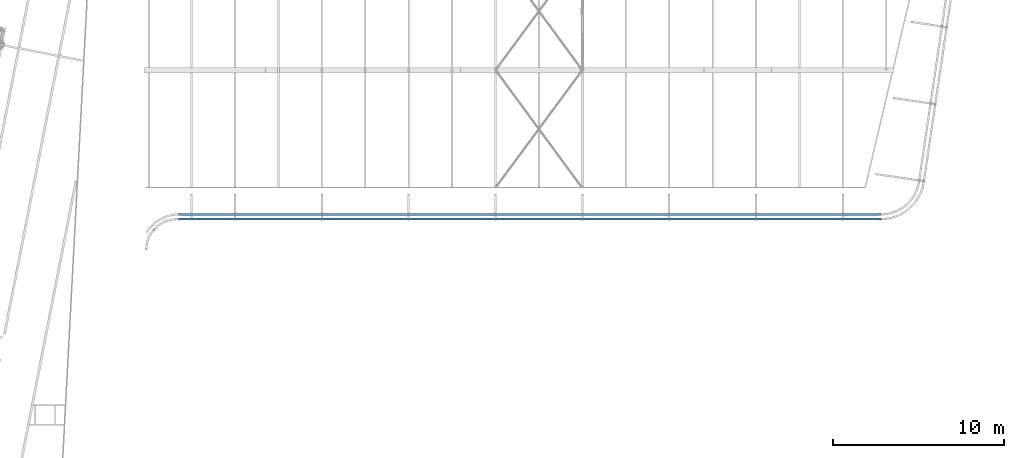
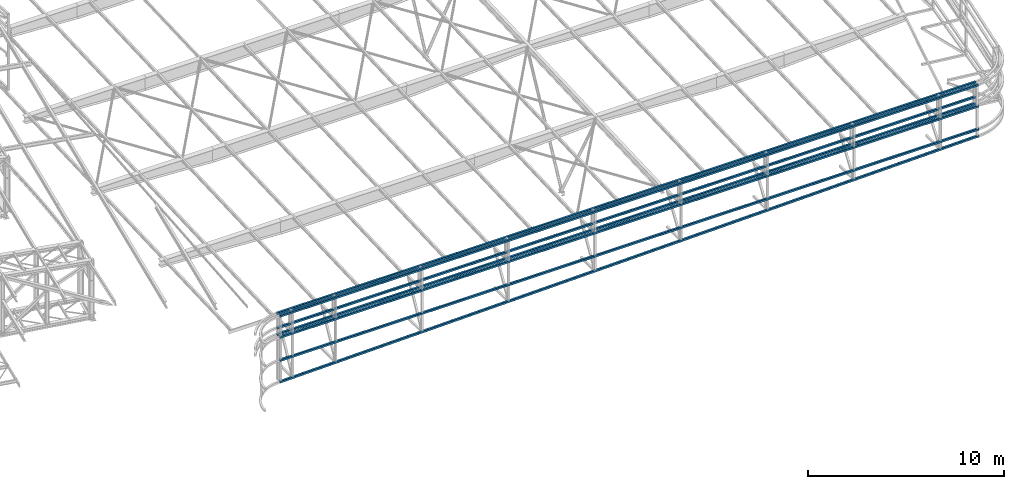
# One storey, part 110 of 215: 7 beams, 7 elements without a shape of their own.
"""IFC2X3 building model written with IfcOpenShell, lengths in millimetres."""

from ifc_helpers import new_model, si_unit, frame, origin_with_axes, origin_2d_with_axis, place, context, subcontext, project, spatial, hollow_rectangle, extrude, material, type_object, element, aggregate, save


model = new_model("IFC2X3")

# Units and contexts
model_context = context("Model", 3, precision=1e-05, world=origin_with_axes())
body_context = subcontext(model_context, "Body", "Model", "MODEL_VIEW")
ifc_project = project(units=[si_unit("LENGTHUNIT", "METRE", prefix="MILLI"), si_unit("AREAUNIT", "SQUARE_METRE"), si_unit("VOLUMEUNIT", "CUBIC_METRE"), si_unit("MASSUNIT", "GRAM", prefix="KILO"), si_unit("TIMEUNIT", "SECOND"), si_unit("PLANEANGLEUNIT", "RADIAN"), si_unit("SOLIDANGLEUNIT", "STERADIAN"), si_unit("THERMODYNAMICTEMPERATUREUNIT", "DEGREE_CELSIUS"), si_unit("LUMINOUSINTENSITYUNIT", "LUMEN")], contexts=[model_context])

# Site, building, storey
site_placement = place(None, origin_with_axes())
site = spatial("IfcSite", under=ifc_project, at=site_placement, CompositionType="ELEMENT")
building_placement = place(site_placement, origin_with_axes())
building = spatial("IfcBuilding", under=site, at=building_placement, Name="Undefined", CompositionType="ELEMENT")
storey_placement = place(building_placement, origin_with_axes())
storey = spatial("IfcBuildingStorey", under=building, at=storey_placement, Name="Undefined", CompositionType="ELEMENT", Elevation=0.0)

# Assembly, beam
assembly_1_placement = place(storey_placement, origin_with_axes())
assembly_1 = element("IfcElementAssembly", 1, at=assembly_1_placement, inside=storey, Name="Steel Assembly", AssemblyPlace="NOTDEFINED", PredefinedType="RIGID_FRAME")
ifc_material = material(Name="STEEL/S275JR")
beam_type = type_object("IfcBeamType", PredefinedType="NOTDEFINED")
beam_1_placement = place(assembly_1_placement, frame((105903.049308731, 33419.9398657618, 3370.28317579678), z_axis=(0.0, 0.0, -1.0), x_axis=(0.999999999998166, 1.91500000001502e-06, 0.0)))
beam_1 = element("IfcBeam", 2, at=beam_1_placement, type_object=beam_type, material=ifc_material, Name="LISSE", context=body_context, shape_type="SweptSolid", body=[
    extrude(hollow_rectangle(XDim=120.0, YDim=120.0, WallThickness=4.0, InnerFilletRadius=4.0, OuterFilletRadius=8.0, at=origin_2d_with_axis()), frame((41081.8175130447, 0.0, -5.18525436023437e-25), z_axis=(-1.0, 0.0, 0.0), x_axis=(-6.93889390390723e-18, -1.0, -3.46944695195361e-18)), (0.0, 0.0, 1.0), 41081.8),
])
aggregate(assembly_1, [beam_1])

assembly_2_placement = place(storey_placement, origin_with_axes())
assembly_2 = element("IfcElementAssembly", 3, at=assembly_2_placement, inside=storey, Name="Steel Assembly", AssemblyPlace="NOTDEFINED", PredefinedType="RIGID_FRAME")
beam_2_placement = place(assembly_2_placement, frame((105903.049308591, 33419.9399101133, 2963.9975133692), z_axis=(0.0, 0.0, -1.0), x_axis=(0.999999999998166, 1.91500000001502e-06, 0.0)))
beam_2 = element("IfcBeam", 4, at=beam_2_placement, type_object=beam_type, material=ifc_material, Name="LISSE", context=body_context, shape_type="SweptSolid", body=[
    extrude(hollow_rectangle(XDim=120.0, YDim=120.0, WallThickness=4.0, InnerFilletRadius=4.0, OuterFilletRadius=8.0, at=origin_2d_with_axis()), frame((41081.8175130447, 0.0, -5.18525436023437e-25), z_axis=(-1.0, 0.0, 0.0), x_axis=(-6.93889390390723e-18, -1.0, -3.46944695195361e-18)), (0.0, 0.0, 1.0), 41081.8),
])
aggregate(assembly_2, [beam_2])

assembly_3_placement = place(storey_placement, origin_with_axes())
assembly_3 = element("IfcElementAssembly", 5, at=assembly_3_placement, inside=storey, Name="Steel Assembly", AssemblyPlace="NOTDEFINED", PredefinedType="RIGID_FRAME")
beam_3_placement = place(assembly_3_placement, frame((105903.049309202, 33419.9410689698, 4279.19102281819), z_axis=(0.0, 0.0, -1.0), x_axis=(0.999999999998166, 1.91500000001502e-06, 0.0)))
beam_3 = element("IfcBeam", 6, at=beam_3_placement, type_object=beam_type, material=ifc_material, Name="LISSE", context=body_context, shape_type="SweptSolid", body=[
    extrude(hollow_rectangle(XDim=120.0, YDim=120.0, WallThickness=4.0, InnerFilletRadius=4.0, OuterFilletRadius=8.0, at=origin_2d_with_axis()), frame((41081.8175130447, 0.0, -5.18525436023437e-25), z_axis=(-1.0, 0.0, 0.0), x_axis=(-6.93889390390723e-18, -1.0, -3.46944695195361e-18)), (0.0, 0.0, 1.0), 41081.8),
])
aggregate(assembly_3, [beam_3])

assembly_4_placement = place(storey_placement, origin_with_axes())
assembly_4 = element("IfcElementAssembly", 7, at=assembly_4_placement, inside=storey, Name="Steel Assembly", AssemblyPlace="NOTDEFINED", PredefinedType="RIGID_FRAME")
beam_4_placement = place(assembly_4_placement, frame((105903.145502831, 33139.9062630844, 1528.87969877852), z_axis=(0.0, 0.0, -1.0), x_axis=(0.999999999998166, 1.91500000001502e-06, 0.0)))
beam_4 = element("IfcBeam", 8, at=beam_4_placement, type_object=beam_type, material=ifc_material, Name="LISSE", context=body_context, shape_type="SweptSolid", body=[
    extrude(hollow_rectangle(XDim=120.0, YDim=120.0, WallThickness=4.0, InnerFilletRadius=4.0, OuterFilletRadius=8.0, at=origin_2d_with_axis()), frame((41110.2784857108, 0.0, 2.27373675443232e-13), z_axis=(-1.0, 0.0, 0.0), x_axis=(-6.93889390390723e-18, -1.0, -3.46944695195361e-18)), (0.0, 0.0, 1.0), 41110.3),
])
aggregate(assembly_4, [beam_4])

assembly_5_placement = place(storey_placement, origin_with_axes())
assembly_5 = element("IfcElementAssembly", 9, at=assembly_5_placement, inside=storey, Name="Steel Assembly", AssemblyPlace="NOTDEFINED", PredefinedType="RIGID_FRAME")
beam_5_placement = place(assembly_5_placement, frame((105903.04907467, 33139.9063071893, 2963.99602443327), z_axis=(0.0, 0.0, -1.0), x_axis=(0.999999999998166, 1.91500000001502e-06, 0.0)))
beam_5 = element("IfcBeam", 10, at=beam_5_placement, type_object=beam_type, material=ifc_material, Name="LISSE", context=body_context, shape_type="SweptSolid", body=[
    extrude(hollow_rectangle(XDim=120.0, YDim=120.0, WallThickness=4.0, InnerFilletRadius=4.0, OuterFilletRadius=8.0, at=origin_2d_with_axis()), frame((41110.2784857108, 0.0, 2.27373675443232e-13), z_axis=(-1.0, 0.0, 0.0), x_axis=(-6.93889390390723e-18, -1.0, -3.46944695195361e-18)), (0.0, 0.0, 1.0), 41110.3),
])
aggregate(assembly_5, [beam_5])

assembly_6_placement = place(storey_placement, origin_with_axes())
assembly_6 = element("IfcElementAssembly", 11, at=assembly_6_placement, inside=storey, Name="Steel Assembly", AssemblyPlace="NOTDEFINED", PredefinedType="RIGID_FRAME")
beam_6_placement = place(assembly_6_placement, frame((105898.659989291, 33139.9064959286, 184.136044920916), z_axis=(0.0223942849900056, 0.0, -0.999749216553725), x_axis=(0.999749216551896, 1.91299999914173e-06, 0.0223942849899625)))
beam_6 = element("IfcBeam", 12, at=beam_6_placement, type_object=beam_type, material=ifc_material, Name="LISSE", context=body_context, shape_type="SweptSolid", body=[
    extrude(hollow_rectangle(XDim=120.0, YDim=120.0, WallThickness=4.0, InnerFilletRadius=4.0, OuterFilletRadius=8.0, at=origin_2d_with_axis()), frame((41110.2784857108, 0.0, 2.27373675443232e-13), z_axis=(-1.0, 0.0, 0.0), x_axis=(-6.93889390390723e-18, -1.0, -3.46944695195361e-18)), (0.0, 0.0, 1.0), 41110.3),
])
aggregate(assembly_6, [beam_6])

assembly_7_placement = place(storey_placement, origin_with_axes())
assembly_7 = element("IfcElementAssembly", 13, at=assembly_7_placement, inside=storey, Name="Steel Assembly", AssemblyPlace="NOTDEFINED", PredefinedType="RIGID_FRAME")
beam_7_placement = place(assembly_7_placement, frame((105903.049072772, 33139.906307524, 4279.19100929583), z_axis=(0.0, 0.0, -1.0), x_axis=(0.999999999998166, 1.91500000001502e-06, 0.0)))
beam_7 = element("IfcBeam", 14, at=beam_7_placement, type_object=beam_type, material=ifc_material, Name="LISSE", context=body_context, shape_type="SweptSolid", body=[
    extrude(hollow_rectangle(XDim=120.0, YDim=120.0, WallThickness=4.0, InnerFilletRadius=4.0, OuterFilletRadius=8.0, at=origin_2d_with_axis()), frame((41081.8235103158, 1.73988290232619e-17, 0.0), z_axis=(-1.0, 0.0, 0.0), x_axis=(-6.93889390390723e-18, -1.0, -3.46944695195361e-18)), (0.0, 0.0, 1.0), 41081.8),
])
aggregate(assembly_7, [beam_7])

save(model, "model.ifc")
